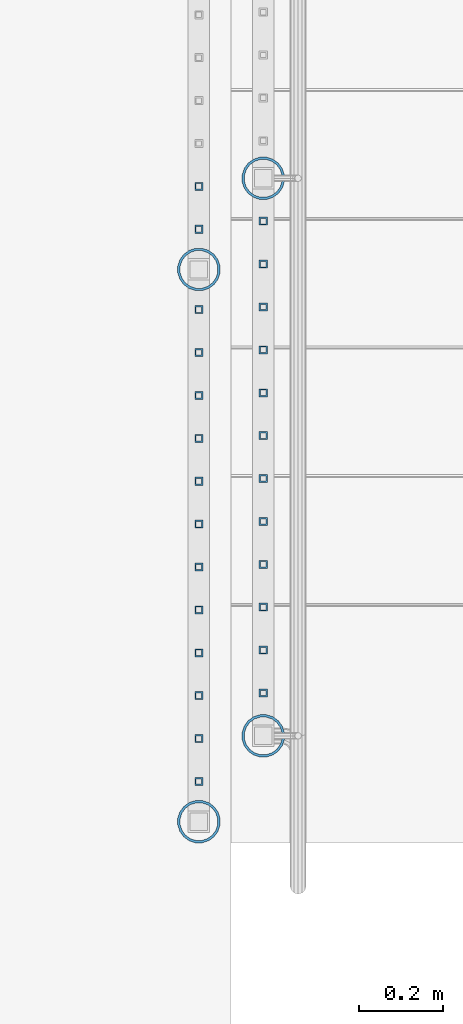
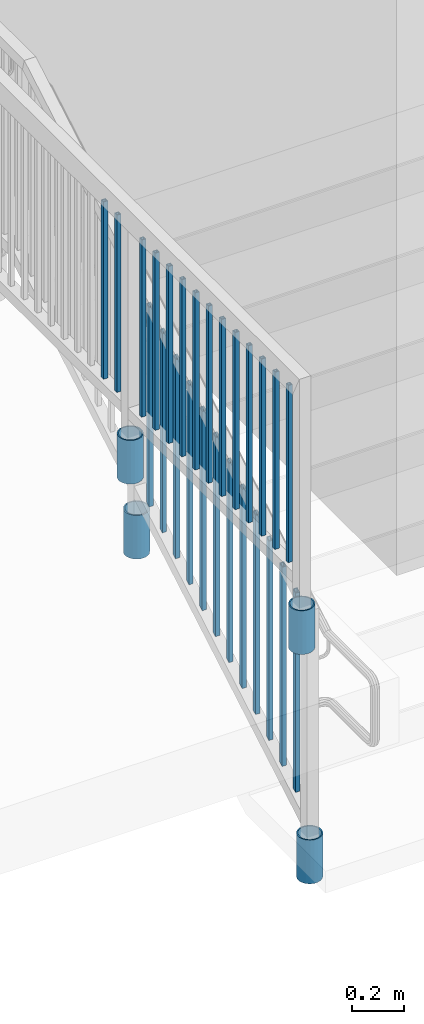
# One storey, part 140 of 975: 30 columns.
"""IFC2X3 building model written with IfcOpenShell, lengths in millimetres."""

from ifc_helpers import new_model, si_unit, frame, origin_with_axes, place, context, subcontext, project, spatial, faceted_brep, material, type_object, element, save


model = new_model("IFC2X3")

# Units and contexts
model_context = context("Model", 3, precision=1e-05, world=origin_with_axes())
body_context = subcontext(model_context, "Body", "Model", "MODEL_VIEW")
ifc_project = project(units=[si_unit("LENGTHUNIT", "METRE", prefix="MILLI"), si_unit("AREAUNIT", "SQUARE_METRE"), si_unit("VOLUMEUNIT", "CUBIC_METRE"), si_unit("MASSUNIT", "GRAM", prefix="KILO"), si_unit("TIMEUNIT", "SECOND"), si_unit("PLANEANGLEUNIT", "RADIAN"), si_unit("SOLIDANGLEUNIT", "STERADIAN"), si_unit("THERMODYNAMICTEMPERATUREUNIT", "DEGREE_CELSIUS"), si_unit("LUMINOUSINTENSITYUNIT", "LUMEN")], contexts=[model_context])

# Site, building, storey
site_placement = place(None, origin_with_axes())
site = spatial("IfcSite", under=ifc_project, at=site_placement, CompositionType="ELEMENT")
building_placement = place(site_placement, origin_with_axes())
building = spatial("IfcBuilding", under=site, at=building_placement, Name="Undefined", CompositionType="ELEMENT")
storey_placement = place(building_placement, origin_with_axes())
storey = spatial("IfcBuildingStorey", under=building, at=storey_placement, Name="Undefined", CompositionType="ELEMENT", Elevation=0.0)

# Columns
ifc_material_1 = material()
column_type_1 = type_object("IfcColumnType", Name="HSS3/4X3/4X.120_TUBES", PredefinedType="NOTDEFINED")
for number, where, z_axis, x_axis, name in (
    (1, (-3190.87499856836, 2032.00035321505, 3661.92557056418), (0.0, 1.0, 0.0), (0.0, 0.0, 1.0), "PICKET"),
    (2, (-3190.87499856836, 1930.40035321505, 3602.6589038485), (0.0, 1.0, 0.0), (0.0, 0.0, 1.0), "PICKET"),
    (3, (-3190.87499856836, 1828.80035321505, 3543.39223713282), (0.0, 1.0, 0.0), (0.0, 0.0, 1.0), "PICKET"),
    (4, (-3190.87499856836, 1727.20035321505, 3484.12557041715), (0.0, 1.0, 0.0), (0.0, 0.0, 1.0), "PICKET"),
    (5, (-3190.87499856836, 1625.60035321505, 3424.85890370147), (0.0, 1.0, 0.0), (0.0, 0.0, 1.0), "PICKET"),
    (6, (-3190.87499856836, 1524.00035321505, 3365.59223698579), (0.0, 1.0, 0.0), (0.0, 0.0, 1.0), "PICKET"),
    (7, (-3190.87499856836, 1422.40035321505, 3306.32557027012), (0.0, 1.0, 0.0), (0.0, 0.0, 1.0), "PICKET"),
    (8, (-3190.87499856836, 1320.80035321505, 3247.05890355444), (0.0, 1.0, 0.0), (0.0, 0.0, 1.0), "PICKET"),
    (9, (-3190.87499856836, 1219.20035321505, 3187.79223683877), (0.0, 1.0, 0.0), (0.0, 0.0, 1.0), "PICKET"),
    (10, (-3190.87499856836, 1117.60035321505, 3128.52557012309), (0.0, 1.0, 0.0), (0.0, 0.0, 1.0), "PICKET"),
    (11, (-3190.87499856836, 1016.00035321505, 3069.25890340741), (0.0, 1.0, 0.0), (0.0, 0.0, 1.0), "PICKET"),
    (12, (-3190.87499856836, 914.400353215052, 3009.99223669174), (0.0, 1.0, 0.0), (0.0, 0.0, 1.0), "PICKET"),
):
    element("IfcColumn", number, at=place(storey_placement, frame(where, z_axis=z_axis, x_axis=x_axis)), inside=storey, type_object=column_type_1, material=ifc_material_1, Name=name, ObjectType="HSS3/4X3/4X.120_TUBES", context=body_context, shape_type="Brep", body=[
        faceted_brep([(-3.70416645998739, 6.34999999999991, -6.34999999999945), (-3.70416623769415, -6.34999999999991, -6.34999999999945), (923.75891709344, -6.34999999999991, -6.35000000014634), (923.758916871147, 6.34999999999991, -6.35000000014634), (3.70416736539664, -6.34999999999991, 6.349999999999), (931.167250696531, -6.34999999999991, 6.34999999985212), (3.70416714310431, 6.34999999999991, 6.349999999999), (931.167250474238, 6.34999999999991, 6.34999999985212), (-5.5562499163334, 9.52500000000009, -9.52499999999964), (5.5562504883037, 9.52500000000009, 9.52499999999918), (933.019333819438, 9.52500000000009, 9.5249999998523), (921.906833414801, 9.52500000000009, -9.52500000014652), (5.55625082174265, -9.52500000000009, 9.52499999999918), (933.019334152877, -9.52500000000009, 9.5249999998523), (-5.55624958289354, -9.52500000000009, -9.52499999999964), (921.90683374824, -9.52500000000009, -9.52500000014652)], [[[0, 1, 2, 3]], [[1, 4, 5, 2]], [[4, 6, 7, 5]], [[6, 0, 3, 7]], [[8, 9, 10, 11]], [[9, 12, 13, 10]], [[12, 14, 15, 13]], [[14, 8, 11, 15]], [[13, 15, 11, 10], [5, 7, 3, 2]], [[14, 12, 9, 8], [6, 4, 1, 0]]]),
    ])
for number, where, z_axis, x_axis, name in (
    (13, (-3343.27499858123, 2114.55033997135, 4254.50002289519), (0.0, 1.0, 0.0), (0.0, 0.0, 1.0), "PICKET"),
    (14, (-3343.27499858123, 2012.95033997135, 4254.50002289519), (0.0, 1.0, 0.0), (0.0, 0.0, 1.0), "PICKET"),
    (15, (-3343.27499858123, 1822.45033966663, 4254.50002270469), (0.0, 1.0, 0.0), (0.0, 0.0, 1.0), "PICKET"),
    (16, (-3343.27499858123, 1720.85033966663, 4254.50002270469), (0.0, 1.0, 0.0), (0.0, 0.0, 1.0), "PICKET"),
    (17, (-3343.27499858123, 1619.25033966663, 4254.50002270469), (0.0, 1.0, 0.0), (0.0, 0.0, 1.0), "PICKET"),
    (18, (-3343.27499858123, 1517.65033966663, 4254.50002270469), (0.0, 1.0, 0.0), (0.0, 0.0, 1.0), "PICKET"),
    (19, (-3343.27499858123, 1416.05033966663, 4254.50002270469), (0.0, 1.0, 0.0), (0.0, 0.0, 1.0), "PICKET"),
    (20, (-3343.27499858123, 1314.45033966663, 4254.50002270469), (0.0, 1.0, 0.0), (0.0, 0.0, 1.0), "PICKET"),
    (21, (-3343.27499858123, 1212.85033966663, 4254.50002270469), (0.0, 1.0, 0.0), (0.0, 0.0, 1.0), "PICKET"),
    (22, (-3343.27499858123, 1111.25033966663, 4254.50002270469), (0.0, 1.0, 0.0), (0.0, 0.0, 1.0), "PICKET"),
    (23, (-3343.27499858123, 1009.65033966663, 4254.50002270469), (0.0, 1.0, 0.0), (0.0, 0.0, 1.0), "PICKET"),
    (24, (-3343.27499858123, 908.050339666629, 4254.50002270469), (0.0, 1.0, 0.0), (0.0, 0.0, 1.0), "PICKET"),
    (25, (-3343.27499858123, 806.450339666629, 4254.50002270469), (0.0, 1.0, 0.0), (0.0, 0.0, 1.0), "PICKET"),
    (26, (-3343.27499858123, 704.850339666629, 4254.50002270469), (0.0, 1.0, 0.0), (0.0, 0.0, 1.0), "PICKET"),
):
    element("IfcColumn", number, at=place(storey_placement, frame(where, z_axis=z_axis, x_axis=x_axis)), inside=storey, type_object=column_type_1, material=ifc_material_1, Name=name, ObjectType="HSS3/4X3/4X.120_TUBES", context=body_context, shape_type="Brep", body=[
        faceted_brep([(0.0, 6.34999999998763, -6.34999999998763), (0.0, -6.35000000000582, -6.34999999998763), (825.49997943247, -6.35000000000582, -6.34999999998763), (825.49997943247, 6.34999999998763, -6.34999999998763), (0.0, -6.34999999998763, 6.34999999998763), (825.49997943247, -6.34999999998763, 6.34999999998763), (0.0, 6.35000000000946, 6.34999999998763), (825.49997943247, 6.35000000000946, 6.34999999998763), (0.0, 9.52499999997963, -9.52499999997963), (0.0, 9.52500000000873, 9.5249999999869), (825.49997943247, 9.52500000000873, 9.5249999999869), (825.49997943247, 9.52499999997963, -9.52499999997963), (0.0, -9.52499999997963, 9.52499999998327), (825.49997943247, -9.52499999997963, 9.52499999998327), (0.0, -9.52500000000873, -9.5249999999869), (825.49997943247, -9.52500000000873, -9.5249999999869)], [[[0, 1, 2, 3]], [[1, 4, 5, 2]], [[4, 6, 7, 5]], [[6, 0, 3, 7]], [[8, 9, 10, 11]], [[9, 12, 13, 10]], [[12, 14, 15, 13]], [[14, 8, 11, 15]], [[13, 15, 11, 10], [5, 7, 3, 2]], [[14, 12, 9, 8], [6, 4, 1, 0]]]),
    ])
ifc_material_2 = material(Name="STEEL/A53")
column_type_2 = type_object("IfcColumnType", Name="PIPE3-1/2STD", PredefinedType="NOTDEFINED")
column_1_placement = place(storey_placement, frame((-3343.2749985941, 1917.70035254451, 3911.60001649977), z_axis=(-0.707106781186601, 0.707106781186494, 2.36468622460961e-14), x_axis=(0.0, 0.0, 1.0)))
element("IfcColumn", 27, at=column_1_placement, inside=storey, type_object=column_type_2, material=ifc_material_2, ObjectType="PIPE3-1/2STD", context=body_context, shape_type="Brep", body=[
    faceted_brep([(0.0, -45.0595999999932, 1.45519152283669e-11), (0.0, -42.8542262016344, 13.924182159768), (203.199999999991, -42.8542262017145, 13.9241821598171), (203.19999999999, -45.0596000000478, 5.82076609134674e-11), (0.0, -36.45398215971, 26.4853683542424), (203.199999999993, -36.45398215981, 26.4853683542988), (0.0, -26.4853683541623, 36.45398215979), (203.199999999995, -26.4853683542788, 36.4539821598537), (0.0, -13.9241821596988, 42.8542262017108), (203.199999999998, -13.9241821598262, 42.8542262017836), (0.0, 3.63797880709171e-11, 45.0596000000514), (203.2, -9.27684595808387e-11, 45.0596000001387), (0.0, 13.9241821597716, 42.8542262017036), (203.200000000003, 13.9241821596443, 42.8542262017927), (0.0, 26.4853683542242, 36.4539821597718), (203.200000000006, 26.4853683541096, 36.4539821598701), (0.0, 36.4539821597537, 26.4853683542206), (203.200000000008, 36.4539821596554, 26.4853683543224), (0.0, 42.8542262016563, 13.9241821597425), (203.200000000009, 42.8542262015817, 13.9241821598443), (0.0, 45.0595999999932, -1.09139364212751e-11), (203.200000000009, 45.0595999999423, 8.9130480773747e-11), (0.0, 42.8542262016344, -13.9241821597643), (203.200000000008, 42.854226201609, -13.9241821596697), (0.0, 36.45398215971, -26.4853683542387), (203.200000000007, 36.4539821597045, -26.4853683541514), (0.0, 26.4853683541623, -36.4539821597864), (203.200000000004, 26.4853683541733, -36.4539821597064), (0.0, 13.9241821596988, -42.8542262017072), (203.200000000002, 13.9241821597225, -42.8542262016381), (0.0, -3.63797880709171e-11, -45.0596000000478), (203.199999999999, -9.09494701772928e-12, -45.0595999999914), (0.0, -13.9241821597716, -42.8542262016963), (203.199999999996, -13.9241821597479, -42.8542262016472), (0.0, -26.4853683542242, -36.4539821597682), (203.199999999993, -26.4853683542133, -36.4539821597227), (0.0, -36.4539821597537, -26.4853683542169), (203.199999999992, -36.4539821597609, -26.4853683541751), (0.0, -42.8542262016563, -13.9241821597352), (203.199999999991, -42.8542262016872, -13.924182159697), (0.0, -50.799999999992, 1.81898940354586e-11), (0.0, -48.3136710278013, -15.6980633142484), (203.199999999989, -48.313671027825, -15.6980633142139), (203.199999999989, -50.8000000000466, 5.63886715099216e-11), (0.0, -41.0980633142644, -29.8594908164741), (203.19999999999, -41.0980633142663, -29.8594908164414), (0.0, -29.859490816485, -41.0980633142826), (203.199999999993, -29.8594908164687, -41.0980633142426), (0.0, -15.6980633142848, -48.313671027845), (203.199999999995, -15.6980633142539, -48.313671027794), (0.0, -4.36557456851006e-11, -50.8000000000575), (203.199999999998, -7.27595761418343e-12, -50.7999999999993), (0.0, 15.6980633142011, -48.3136710278523), (203.200000000002, 15.6980633142375, -48.3136710277831), (0.0, 29.8594908164159, -41.0980633143045), (203.200000000005, 29.8594908164378, -41.0980633142226), (0.0, 41.0980633142135, -29.8594908165032), (203.200000000008, 41.0980633142171, -29.8594908164141), (0.0, 48.3136710277722, -15.6980633142775), (203.200000000009, 48.3136710277504, -15.6980633141811), (0.0, 50.799999999992, -1.45519152283669e-11), (203.20000000001, 50.7999999999411, 9.09494701772928e-11), (0.0, 48.313671027794, 15.6980633142521), (203.20000000001, 48.3136710277213, 15.6980633143594), (0.0, 41.0980633142644, 29.8594908164814), (203.200000000008, 41.0980633141626, 29.8594908165887), (0.0, 29.859490816485, 41.0980633142863), (203.200000000007, 29.8594908163632, 41.0980633143899), (0.0, 15.6980633142848, 48.3136710278486), (203.200000000004, 15.6980633141484, 48.3136710279414), (0.0, 4.00177668780088e-11, 50.8000000000611), (203.200000000001, -9.82254277914762e-11, 50.8000000001466), (0.0, -15.6980633142011, 48.3136710278559), (203.199999999997, -15.698063314343, 48.3136710279305), (0.0, -29.8594908164159, 41.0980633143081), (203.199999999994, -29.8594908165433, 41.0980633143681), (0.0, -41.0980633142171, 29.8594908165069), (203.199999999992, -41.0980633143226, 29.8594908165596), (0.0, -48.3136710277722, 15.6980633142812), (203.19999999999, -48.3136710278559, 15.6980633143285)], [[[0, 1, 2, 3]], [[1, 4, 5, 2]], [[4, 6, 7, 5]], [[6, 8, 9, 7]], [[8, 10, 11, 9]], [[10, 12, 13, 11]], [[12, 14, 15, 13]], [[14, 16, 17, 15]], [[16, 18, 19, 17]], [[18, 20, 21, 19]], [[20, 22, 23, 21]], [[22, 24, 25, 23]], [[24, 26, 27, 25]], [[26, 28, 29, 27]], [[28, 30, 31, 29]], [[30, 32, 33, 31]], [[32, 34, 35, 33]], [[34, 36, 37, 35]], [[36, 38, 39, 37]], [[38, 0, 3, 39]], [[40, 41, 42, 43]], [[41, 44, 45, 42]], [[44, 46, 47, 45]], [[46, 48, 49, 47]], [[48, 50, 51, 49]], [[50, 52, 53, 51]], [[52, 54, 55, 53]], [[54, 56, 57, 55]], [[56, 58, 59, 57]], [[58, 60, 61, 59]], [[60, 62, 63, 61]], [[62, 64, 65, 63]], [[64, 66, 67, 65]], [[66, 68, 69, 67]], [[68, 70, 71, 69]], [[70, 72, 73, 71]], [[72, 74, 75, 73]], [[74, 76, 77, 75]], [[76, 78, 79, 77]], [[78, 40, 43, 79]], [[45, 47, 49, 51, 53, 55, 57, 59, 61, 63, 65, 67, 69, 71, 73, 75, 77, 79, 43, 42], [5, 7, 9, 11, 13, 15, 17, 19, 21, 23, 25, 27, 29, 31, 33, 35, 37, 39, 3, 2]], [[78, 76, 74, 72, 70, 68, 66, 64, 62, 60, 58, 56, 54, 52, 50, 48, 46, 44, 41, 40], [38, 36, 34, 32, 30, 28, 26, 24, 22, 20, 18, 16, 14, 12, 10, 8, 6, 4, 1, 0]]]),
])
column_2_placement = place(storey_placement, frame((-3343.2749985941, 609.600352239831, 3911.60002239251), z_axis=(-0.707106781186601, 0.707106781186494, 2.36468622460961e-14), x_axis=(0.0, 0.0, 1.0)))
element("IfcColumn", 28, at=column_2_placement, inside=storey, type_object=column_type_2, material=ifc_material_2, ObjectType="PIPE3-1/2STD", context=body_context, shape_type="Brep", body=[
    faceted_brep([(0.0, -45.0595999999932, 1.45519152283669e-11), (0.0, -42.8542262016344, 13.924182159768), (203.199999999991, -42.8542262017145, 13.9241821598171), (203.19999999999, -45.0596000000478, 5.82076609134674e-11), (0.0, -36.45398215971, 26.4853683542424), (203.199999999993, -36.45398215981, 26.4853683542988), (0.0, -26.4853683541623, 36.45398215979), (203.199999999995, -26.4853683542788, 36.4539821598537), (0.0, -13.9241821596988, 42.8542262017108), (203.199999999998, -13.9241821598262, 42.8542262017836), (0.0, 3.63797880709171e-11, 45.0596000000514), (203.2, -9.27684595808387e-11, 45.0596000001387), (0.0, 13.9241821597716, 42.8542262017036), (203.200000000003, 13.9241821596443, 42.8542262017927), (0.0, 26.4853683542242, 36.4539821597718), (203.200000000006, 26.4853683541096, 36.4539821598701), (0.0, 36.4539821597537, 26.4853683542206), (203.200000000008, 36.4539821596554, 26.4853683543224), (0.0, 42.8542262016563, 13.9241821597425), (203.200000000009, 42.8542262015817, 13.9241821598443), (0.0, 45.0595999999932, -1.09139364212751e-11), (203.200000000009, 45.0595999999423, 8.9130480773747e-11), (0.0, 42.8542262016344, -13.9241821597643), (203.200000000008, 42.854226201609, -13.9241821596697), (0.0, 36.45398215971, -26.4853683542387), (203.200000000007, 36.4539821597045, -26.4853683541514), (0.0, 26.4853683541623, -36.4539821597864), (203.200000000004, 26.4853683541733, -36.4539821597064), (0.0, 13.9241821596988, -42.8542262017072), (203.200000000002, 13.9241821597225, -42.8542262016381), (0.0, -3.63797880709171e-11, -45.0596000000478), (203.199999999999, -9.09494701772928e-12, -45.0595999999914), (0.0, -13.9241821597716, -42.8542262016963), (203.199999999996, -13.9241821597479, -42.8542262016472), (0.0, -26.4853683542242, -36.4539821597682), (203.199999999993, -26.4853683542133, -36.4539821597227), (0.0, -36.4539821597537, -26.4853683542169), (203.199999999992, -36.4539821597609, -26.4853683541751), (0.0, -42.8542262016563, -13.9241821597352), (203.199999999991, -42.8542262016872, -13.924182159697), (0.0, -50.799999999992, 1.81898940354586e-11), (0.0, -48.3136710278013, -15.6980633142484), (203.199999999989, -48.313671027825, -15.6980633142139), (203.199999999989, -50.8000000000466, 5.63886715099216e-11), (0.0, -41.0980633142644, -29.8594908164741), (203.19999999999, -41.0980633142663, -29.8594908164414), (0.0, -29.859490816485, -41.0980633142826), (203.199999999993, -29.8594908164687, -41.0980633142426), (0.0, -15.6980633142848, -48.313671027845), (203.199999999995, -15.6980633142539, -48.313671027794), (0.0, -4.36557456851006e-11, -50.8000000000575), (203.199999999998, -7.27595761418343e-12, -50.7999999999993), (0.0, 15.6980633142011, -48.3136710278523), (203.200000000002, 15.6980633142375, -48.3136710277831), (0.0, 29.8594908164159, -41.0980633143045), (203.200000000005, 29.8594908164378, -41.0980633142226), (0.0, 41.0980633142135, -29.8594908165032), (203.200000000008, 41.0980633142171, -29.8594908164141), (0.0, 48.3136710277722, -15.6980633142775), (203.200000000009, 48.3136710277504, -15.6980633141811), (0.0, 50.799999999992, -1.45519152283669e-11), (203.20000000001, 50.7999999999411, 9.09494701772928e-11), (0.0, 48.313671027794, 15.6980633142521), (203.20000000001, 48.3136710277213, 15.6980633143594), (0.0, 41.0980633142644, 29.8594908164814), (203.200000000008, 41.0980633141626, 29.8594908165887), (0.0, 29.859490816485, 41.0980633142863), (203.200000000007, 29.8594908163632, 41.0980633143899), (0.0, 15.6980633142848, 48.3136710278486), (203.200000000004, 15.6980633141484, 48.3136710279414), (0.0, 4.00177668780088e-11, 50.8000000000611), (203.200000000001, -9.82254277914762e-11, 50.8000000001466), (0.0, -15.6980633142011, 48.3136710278559), (203.199999999997, -15.698063314343, 48.3136710279305), (0.0, -29.8594908164159, 41.0980633143081), (203.199999999994, -29.8594908165433, 41.0980633143681), (0.0, -41.0980633142171, 29.8594908165069), (203.199999999992, -41.0980633143226, 29.8594908165596), (0.0, -48.3136710277722, 15.6980633142812), (203.19999999999, -48.3136710278559, 15.6980633143285)], [[[0, 1, 2, 3]], [[1, 4, 5, 2]], [[4, 6, 7, 5]], [[6, 8, 9, 7]], [[8, 10, 11, 9]], [[10, 12, 13, 11]], [[12, 14, 15, 13]], [[14, 16, 17, 15]], [[16, 18, 19, 17]], [[18, 20, 21, 19]], [[20, 22, 23, 21]], [[22, 24, 25, 23]], [[24, 26, 27, 25]], [[26, 28, 29, 27]], [[28, 30, 31, 29]], [[30, 32, 33, 31]], [[32, 34, 35, 33]], [[34, 36, 37, 35]], [[36, 38, 39, 37]], [[38, 0, 3, 39]], [[40, 41, 42, 43]], [[41, 44, 45, 42]], [[44, 46, 47, 45]], [[46, 48, 49, 47]], [[48, 50, 51, 49]], [[50, 52, 53, 51]], [[52, 54, 55, 53]], [[54, 56, 57, 55]], [[56, 58, 59, 57]], [[58, 60, 61, 59]], [[60, 62, 63, 61]], [[62, 64, 65, 63]], [[64, 66, 67, 65]], [[66, 68, 69, 67]], [[68, 70, 71, 69]], [[70, 72, 73, 71]], [[72, 74, 75, 73]], [[74, 76, 77, 75]], [[76, 78, 79, 77]], [[78, 40, 43, 79]], [[45, 47, 49, 51, 53, 55, 57, 59, 61, 63, 65, 67, 69, 71, 73, 75, 77, 79, 43, 42], [5, 7, 9, 11, 13, 15, 17, 19, 21, 23, 25, 27, 29, 31, 33, 35, 37, 39, 3, 2]], [[78, 76, 74, 72, 70, 68, 66, 64, 62, 60, 58, 56, 54, 52, 50, 48, 46, 44, 41, 40], [38, 36, 34, 32, 30, 28, 26, 24, 22, 20, 18, 16, 14, 12, 10, 8, 6, 4, 1, 0]]]),
])
column_3_placement = place(storey_placement, frame((-3190.87499858123, 2133.60036285013, 3378.20002478374), z_axis=(-0.707106781186601, 0.707106781186494, 2.36468622460961e-14), x_axis=(0.0, 0.0, 1.0)))
element("IfcColumn", 29, at=column_3_placement, inside=storey, type_object=column_type_2, material=ifc_material_2, ObjectType="PIPE3-1/2STD", context=body_context, shape_type="Brep", body=[
    faceted_brep([(0.0, -45.0595999999932, 1.45519152283669e-11), (0.0, -42.8542262016344, 13.924182159768), (203.199999999991, -42.8542262017145, 13.9241821598171), (203.19999999999, -45.0596000000478, 5.82076609134674e-11), (0.0, -36.45398215971, 26.4853683542424), (203.199999999993, -36.45398215981, 26.4853683542988), (0.0, -26.4853683541623, 36.45398215979), (203.199999999995, -26.4853683542788, 36.4539821598537), (0.0, -13.9241821596988, 42.8542262017108), (203.199999999998, -13.9241821598262, 42.8542262017836), (0.0, 3.63797880709171e-11, 45.0596000000514), (203.2, -9.27684595808387e-11, 45.0596000001387), (0.0, 13.9241821597716, 42.8542262017036), (203.200000000003, 13.9241821596443, 42.8542262017927), (0.0, 26.4853683542242, 36.4539821597718), (203.200000000006, 26.4853683541096, 36.4539821598701), (0.0, 36.4539821597537, 26.4853683542206), (203.200000000008, 36.4539821596554, 26.4853683543224), (0.0, 42.8542262016563, 13.9241821597425), (203.200000000009, 42.8542262015817, 13.9241821598443), (0.0, 45.0595999999932, -1.09139364212751e-11), (203.200000000009, 45.0595999999423, 8.9130480773747e-11), (0.0, 42.8542262016344, -13.9241821597643), (203.200000000008, 42.854226201609, -13.9241821596697), (0.0, 36.45398215971, -26.4853683542387), (203.200000000007, 36.4539821597045, -26.4853683541514), (0.0, 26.4853683541623, -36.4539821597864), (203.200000000004, 26.4853683541733, -36.4539821597064), (0.0, 13.9241821596988, -42.8542262017072), (203.200000000002, 13.9241821597225, -42.8542262016381), (0.0, -3.63797880709171e-11, -45.0596000000478), (203.199999999999, -9.09494701772928e-12, -45.0595999999914), (0.0, -13.9241821597716, -42.8542262016963), (203.199999999996, -13.9241821597479, -42.8542262016472), (0.0, -26.4853683542242, -36.4539821597682), (203.199999999993, -26.4853683542133, -36.4539821597227), (0.0, -36.4539821597537, -26.4853683542169), (203.199999999992, -36.4539821597609, -26.4853683541751), (0.0, -42.8542262016563, -13.9241821597352), (203.199999999991, -42.8542262016872, -13.924182159697), (0.0, -50.799999999992, 1.81898940354586e-11), (0.0, -48.3136710278013, -15.6980633142484), (203.199999999989, -48.313671027825, -15.6980633142139), (203.199999999989, -50.8000000000466, 5.63886715099216e-11), (0.0, -41.0980633142644, -29.8594908164741), (203.19999999999, -41.0980633142663, -29.8594908164414), (0.0, -29.859490816485, -41.0980633142826), (203.199999999993, -29.8594908164687, -41.0980633142426), (0.0, -15.6980633142848, -48.313671027845), (203.199999999995, -15.6980633142539, -48.313671027794), (0.0, -4.36557456851006e-11, -50.8000000000575), (203.199999999998, -7.27595761418343e-12, -50.7999999999993), (0.0, 15.6980633142011, -48.3136710278523), (203.200000000002, 15.6980633142375, -48.3136710277831), (0.0, 29.8594908164159, -41.0980633143045), (203.200000000005, 29.8594908164378, -41.0980633142226), (0.0, 41.0980633142135, -29.8594908165032), (203.200000000008, 41.0980633142171, -29.8594908164141), (0.0, 48.3136710277722, -15.6980633142775), (203.200000000009, 48.3136710277504, -15.6980633141811), (0.0, 50.799999999992, -1.45519152283669e-11), (203.20000000001, 50.7999999999411, 9.09494701772928e-11), (0.0, 48.313671027794, 15.6980633142521), (203.20000000001, 48.3136710277213, 15.6980633143594), (0.0, 41.0980633142644, 29.8594908164814), (203.200000000008, 41.0980633141626, 29.8594908165887), (0.0, 29.859490816485, 41.0980633142863), (203.200000000007, 29.8594908163632, 41.0980633143899), (0.0, 15.6980633142848, 48.3136710278486), (203.200000000004, 15.6980633141484, 48.3136710279414), (0.0, 4.00177668780088e-11, 50.8000000000611), (203.200000000001, -9.82254277914762e-11, 50.8000000001466), (0.0, -15.6980633142011, 48.3136710278559), (203.199999999997, -15.698063314343, 48.3136710279305), (0.0, -29.8594908164159, 41.0980633143081), (203.199999999994, -29.8594908165433, 41.0980633143681), (0.0, -41.0980633142171, 29.8594908165069), (203.199999999992, -41.0980633143226, 29.8594908165596), (0.0, -48.3136710277722, 15.6980633142812), (203.19999999999, -48.3136710278559, 15.6980633143285)], [[[0, 1, 2, 3]], [[1, 4, 5, 2]], [[4, 6, 7, 5]], [[6, 8, 9, 7]], [[8, 10, 11, 9]], [[10, 12, 13, 11]], [[12, 14, 15, 13]], [[14, 16, 17, 15]], [[16, 18, 19, 17]], [[18, 20, 21, 19]], [[20, 22, 23, 21]], [[22, 24, 25, 23]], [[24, 26, 27, 25]], [[26, 28, 29, 27]], [[28, 30, 31, 29]], [[30, 32, 33, 31]], [[32, 34, 35, 33]], [[34, 36, 37, 35]], [[36, 38, 39, 37]], [[38, 0, 3, 39]], [[40, 41, 42, 43]], [[41, 44, 45, 42]], [[44, 46, 47, 45]], [[46, 48, 49, 47]], [[48, 50, 51, 49]], [[50, 52, 53, 51]], [[52, 54, 55, 53]], [[54, 56, 57, 55]], [[56, 58, 59, 57]], [[58, 60, 61, 59]], [[60, 62, 63, 61]], [[62, 64, 65, 63]], [[64, 66, 67, 65]], [[66, 68, 69, 67]], [[68, 70, 71, 69]], [[70, 72, 73, 71]], [[72, 74, 75, 73]], [[74, 76, 77, 75]], [[76, 78, 79, 77]], [[78, 40, 43, 79]], [[45, 47, 49, 51, 53, 55, 57, 59, 61, 63, 65, 67, 69, 71, 73, 75, 77, 79, 43, 42], [5, 7, 9, 11, 13, 15, 17, 19, 21, 23, 25, 27, 29, 31, 33, 35, 37, 39, 3, 2]], [[78, 76, 74, 72, 70, 68, 66, 64, 62, 60, 58, 56, 54, 52, 50, 48, 46, 44, 41, 40], [38, 36, 34, 32, 30, 28, 26, 24, 22, 20, 18, 16, 14, 12, 10, 8, 6, 4, 1, 0]]]),
])
column_4_placement = place(storey_placement, frame((-3190.87499858123, 812.800352239827, 2666.99998821452), z_axis=(-0.707106781186601, 0.707106781186494, 2.36468622460961e-14), x_axis=(0.0, 0.0, 1.0)))
element("IfcColumn", 30, at=column_4_placement, inside=storey, type_object=column_type_2, material=ifc_material_2, ObjectType="PIPE3-1/2STD", context=body_context, shape_type="Brep", body=[
    faceted_brep([(0.0, -45.0595999999932, 1.45519152283669e-11), (0.0, -42.8542262016344, 13.924182159768), (203.199999999991, -42.8542262017145, 13.9241821598171), (203.19999999999, -45.0596000000478, 5.82076609134674e-11), (0.0, -36.45398215971, 26.4853683542424), (203.199999999993, -36.45398215981, 26.4853683542988), (0.0, -26.4853683541623, 36.45398215979), (203.199999999995, -26.4853683542788, 36.4539821598537), (0.0, -13.9241821596988, 42.8542262017108), (203.199999999998, -13.9241821598262, 42.8542262017836), (0.0, 3.63797880709171e-11, 45.0596000000514), (203.2, -9.27684595808387e-11, 45.0596000001387), (0.0, 13.9241821597716, 42.8542262017036), (203.200000000003, 13.9241821596443, 42.8542262017927), (0.0, 26.4853683542242, 36.4539821597718), (203.200000000006, 26.4853683541096, 36.4539821598701), (0.0, 36.4539821597537, 26.4853683542206), (203.200000000008, 36.4539821596554, 26.4853683543224), (0.0, 42.8542262016563, 13.9241821597425), (203.200000000009, 42.8542262015817, 13.9241821598443), (0.0, 45.0595999999932, -1.09139364212751e-11), (203.200000000009, 45.0595999999423, 8.9130480773747e-11), (0.0, 42.8542262016344, -13.9241821597643), (203.200000000008, 42.854226201609, -13.9241821596697), (0.0, 36.45398215971, -26.4853683542387), (203.200000000007, 36.4539821597045, -26.4853683541514), (0.0, 26.4853683541623, -36.4539821597864), (203.200000000004, 26.4853683541733, -36.4539821597064), (0.0, 13.9241821596988, -42.8542262017072), (203.200000000002, 13.9241821597225, -42.8542262016381), (0.0, -3.63797880709171e-11, -45.0596000000478), (203.199999999999, -9.09494701772928e-12, -45.0595999999914), (0.0, -13.9241821597716, -42.8542262016963), (203.199999999996, -13.9241821597479, -42.8542262016472), (0.0, -26.4853683542242, -36.4539821597682), (203.199999999993, -26.4853683542133, -36.4539821597227), (0.0, -36.4539821597537, -26.4853683542169), (203.199999999992, -36.4539821597609, -26.4853683541751), (0.0, -42.8542262016563, -13.9241821597352), (203.199999999991, -42.8542262016872, -13.924182159697), (0.0, -50.799999999992, 1.81898940354586e-11), (0.0, -48.3136710278013, -15.6980633142484), (203.199999999989, -48.313671027825, -15.6980633142139), (203.199999999989, -50.8000000000466, 5.63886715099216e-11), (0.0, -41.0980633142644, -29.8594908164741), (203.19999999999, -41.0980633142663, -29.8594908164414), (0.0, -29.859490816485, -41.0980633142826), (203.199999999993, -29.8594908164687, -41.0980633142426), (0.0, -15.6980633142848, -48.313671027845), (203.199999999995, -15.6980633142539, -48.313671027794), (0.0, -4.36557456851006e-11, -50.8000000000575), (203.199999999998, -7.27595761418343e-12, -50.7999999999993), (0.0, 15.6980633142011, -48.3136710278523), (203.200000000002, 15.6980633142375, -48.3136710277831), (0.0, 29.8594908164159, -41.0980633143045), (203.200000000005, 29.8594908164378, -41.0980633142226), (0.0, 41.0980633142135, -29.8594908165032), (203.200000000008, 41.0980633142171, -29.8594908164141), (0.0, 48.3136710277722, -15.6980633142775), (203.200000000009, 48.3136710277504, -15.6980633141811), (0.0, 50.799999999992, -1.45519152283669e-11), (203.20000000001, 50.7999999999411, 9.09494701772928e-11), (0.0, 48.313671027794, 15.6980633142521), (203.20000000001, 48.3136710277213, 15.6980633143594), (0.0, 41.0980633142644, 29.8594908164814), (203.200000000008, 41.0980633141626, 29.8594908165887), (0.0, 29.859490816485, 41.0980633142863), (203.200000000007, 29.8594908163632, 41.0980633143899), (0.0, 15.6980633142848, 48.3136710278486), (203.200000000004, 15.6980633141484, 48.3136710279414), (0.0, 4.00177668780088e-11, 50.8000000000611), (203.200000000001, -9.82254277914762e-11, 50.8000000001466), (0.0, -15.6980633142011, 48.3136710278559), (203.199999999997, -15.698063314343, 48.3136710279305), (0.0, -29.8594908164159, 41.0980633143081), (203.199999999994, -29.8594908165433, 41.0980633143681), (0.0, -41.0980633142171, 29.8594908165069), (203.199999999992, -41.0980633143226, 29.8594908165596), (0.0, -48.3136710277722, 15.6980633142812), (203.19999999999, -48.3136710278559, 15.6980633143285)], [[[0, 1, 2, 3]], [[1, 4, 5, 2]], [[4, 6, 7, 5]], [[6, 8, 9, 7]], [[8, 10, 11, 9]], [[10, 12, 13, 11]], [[12, 14, 15, 13]], [[14, 16, 17, 15]], [[16, 18, 19, 17]], [[18, 20, 21, 19]], [[20, 22, 23, 21]], [[22, 24, 25, 23]], [[24, 26, 27, 25]], [[26, 28, 29, 27]], [[28, 30, 31, 29]], [[30, 32, 33, 31]], [[32, 34, 35, 33]], [[34, 36, 37, 35]], [[36, 38, 39, 37]], [[38, 0, 3, 39]], [[40, 41, 42, 43]], [[41, 44, 45, 42]], [[44, 46, 47, 45]], [[46, 48, 49, 47]], [[48, 50, 51, 49]], [[50, 52, 53, 51]], [[52, 54, 55, 53]], [[54, 56, 57, 55]], [[56, 58, 59, 57]], [[58, 60, 61, 59]], [[60, 62, 63, 61]], [[62, 64, 65, 63]], [[64, 66, 67, 65]], [[66, 68, 69, 67]], [[68, 70, 71, 69]], [[70, 72, 73, 71]], [[72, 74, 75, 73]], [[74, 76, 77, 75]], [[76, 78, 79, 77]], [[78, 40, 43, 79]], [[45, 47, 49, 51, 53, 55, 57, 59, 61, 63, 65, 67, 69, 71, 73, 75, 77, 79, 43, 42], [5, 7, 9, 11, 13, 15, 17, 19, 21, 23, 25, 27, 29, 31, 33, 35, 37, 39, 3, 2]], [[78, 76, 74, 72, 70, 68, 66, 64, 62, 60, 58, 56, 54, 52, 50, 48, 46, 44, 41, 40], [38, 36, 34, 32, 30, 28, 26, 24, 22, 20, 18, 16, 14, 12, 10, 8, 6, 4, 1, 0]]]),
])

save(model, "model.ifc")
